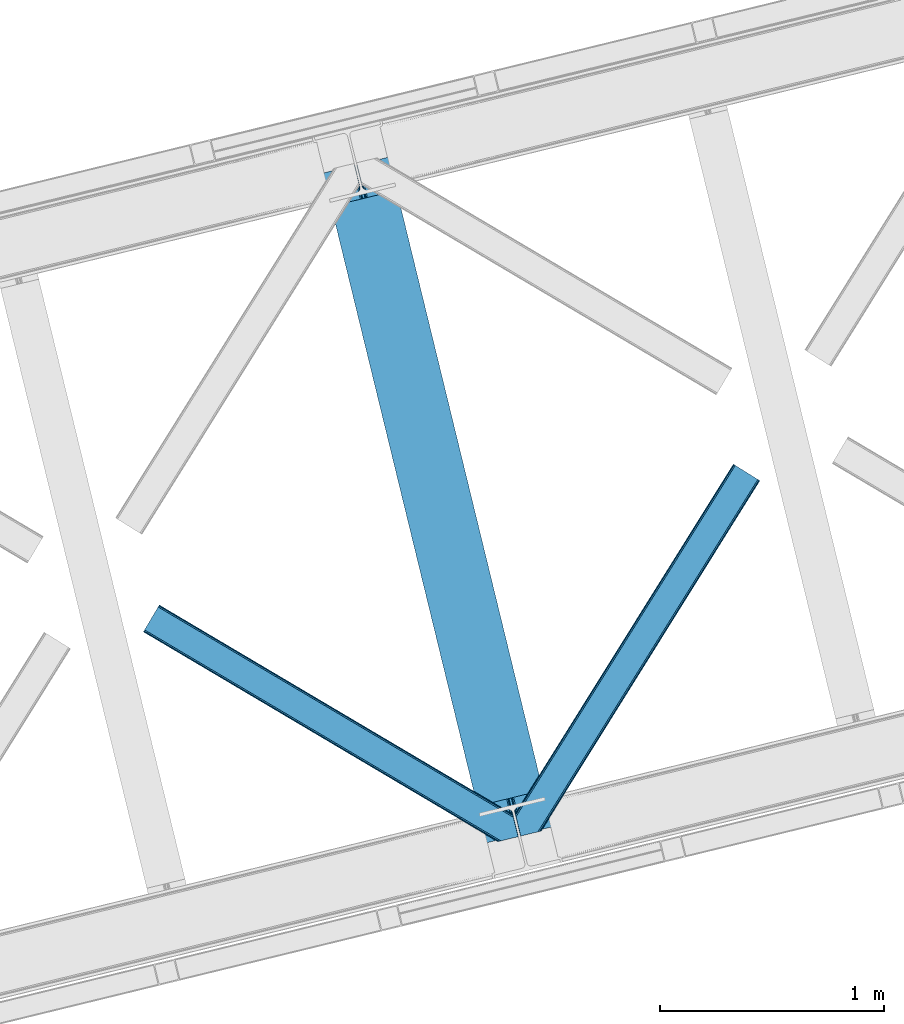
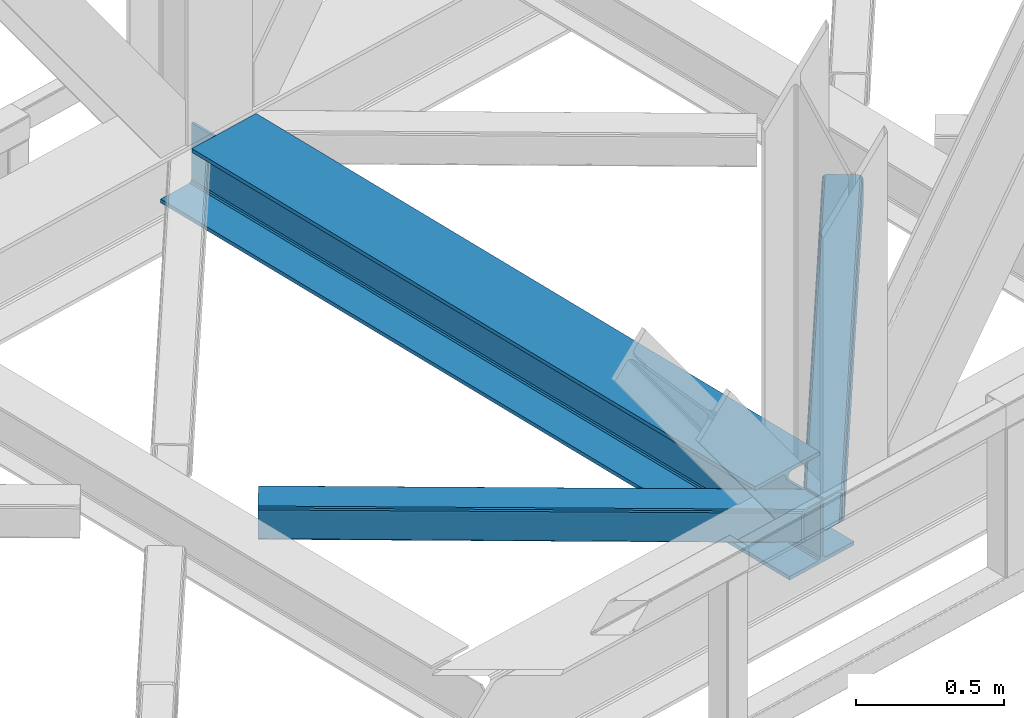
# One storey, part 62 of 92: 2 members, 1 beam.
"""IFC4 building model written with IfcOpenShell, lengths in millimetres."""

from ifc_helpers import new_model, entity, si_unit, converted_unit, derived_unit, direction, frame, origin, place, context, subcontext, project, spatial, triangles, polygons, material, type_object, element, save


model = new_model("IFC4")

# Units and contexts
model_context = context("Model", 3, precision=0.01, world=origin(), true_north=direction((6.12303176911189e-17, 1.0)))
plan_context = context("Plan", 3, precision=0.01, world=origin(), true_north=direction((6.12303176911189e-17, 1.0)))
body_context = subcontext(model_context, "Body", "Model", "MODEL_VIEW")
ifc_project = project(units=[si_unit("LENGTHUNIT", "METRE", prefix="MILLI"), si_unit("AREAUNIT", "SQUARE_METRE"), si_unit("VOLUMEUNIT", "CUBIC_METRE"), converted_unit("PLANEANGLEUNIT", "DEGREE", entity("IfcRatioMeasure", 0.0174532925199433), si_unit("PLANEANGLEUNIT", "RADIAN"), dimensions=[0, 0, 0, 0, 0, 0, 0]), si_unit("MASSUNIT", "GRAM", prefix="KILO"), derived_unit("MASSDENSITYUNIT", [(si_unit("MASSUNIT", "GRAM", prefix="KILO"), 1), (si_unit("LENGTHUNIT", "METRE"), -3)]), derived_unit("MOMENTOFINERTIAUNIT", [(si_unit("LENGTHUNIT", "METRE"), 4)]), si_unit("TIMEUNIT", "SECOND"), si_unit("FREQUENCYUNIT", "HERTZ"), si_unit("THERMODYNAMICTEMPERATUREUNIT", "DEGREE_CELSIUS"), derived_unit("THERMALTRANSMITTANCEUNIT", [(si_unit("MASSUNIT", "GRAM", prefix="KILO"), 1), (si_unit("THERMODYNAMICTEMPERATUREUNIT", "KELVIN"), -1), (si_unit("TIMEUNIT", "SECOND"), -3)]), derived_unit("VOLUMETRICFLOWRATEUNIT", [(si_unit("LENGTHUNIT", "METRE"), 3), (si_unit("TIMEUNIT", "SECOND"), -1)]), derived_unit("MASSFLOWRATEUNIT", [(si_unit("MASSUNIT", "GRAM", prefix="KILO"), 1), (si_unit("TIMEUNIT", "SECOND"), -1)]), derived_unit("ROTATIONALFREQUENCYUNIT", [(si_unit("TIMEUNIT", "SECOND"), -1)]), si_unit("ELECTRICCURRENTUNIT", "AMPERE"), si_unit("ELECTRICVOLTAGEUNIT", "VOLT"), si_unit("POWERUNIT", "WATT"), si_unit("FORCEUNIT", "NEWTON", prefix="KILO"), si_unit("ILLUMINANCEUNIT", "LUX"), si_unit("LUMINOUSFLUXUNIT", "LUMEN"), si_unit("LUMINOUSINTENSITYUNIT", "CANDELA"), derived_unit("USERDEFINED", [(si_unit("MASSUNIT", "GRAM", prefix="KILO"), -1), (si_unit("LENGTHUNIT", "METRE"), -2), (si_unit("TIMEUNIT", "SECOND"), 3), (si_unit("LUMINOUSFLUXUNIT", "LUMEN"), 1)]), derived_unit("LINEARVELOCITYUNIT", [(si_unit("LENGTHUNIT", "METRE"), 1), (si_unit("TIMEUNIT", "SECOND"), -1)]), si_unit("PRESSUREUNIT", "PASCAL"), derived_unit("USERDEFINED", [(si_unit("LENGTHUNIT", "METRE"), -2), (si_unit("MASSUNIT", "GRAM", prefix="KILO"), 1), (si_unit("TIMEUNIT", "SECOND"), -2)]), derived_unit("LINEARFORCEUNIT", [(si_unit("MASSUNIT", "GRAM", prefix="KILO"), 1), (si_unit("LENGTHUNIT", "METRE"), 1), (si_unit("TIMEUNIT", "SECOND"), -2), (si_unit("LENGTHUNIT", "METRE"), -1)]), derived_unit("PLANARFORCEUNIT", [(si_unit("MASSUNIT", "GRAM", prefix="KILO"), 1), (si_unit("LENGTHUNIT", "METRE"), 1), (si_unit("TIMEUNIT", "SECOND"), -2), (si_unit("LENGTHUNIT", "METRE"), -2)])], contexts=[model_context, plan_context])

# Site, building, storey
site_placement = place(None, origin())
site = spatial("IfcSite", under=ifc_project, at=site_placement, CompositionType="ELEMENT")
building_placement = place(site_placement, origin())
building = spatial("IfcBuilding", under=site, at=building_placement, CompositionType="ELEMENT")
storey_placement = place(building_placement, frame((0.0, 0.0, 15900.0)))
storey = spatial("IfcBuildingStorey", under=building, at=storey_placement, Name="05", CompositionType="ELEMENT", Elevation=15900.0)

# Beam
ifc_material = material(Name="Metal painted (White)")
beam_type = type_object("IfcBeamType", PredefinedType="BEAM")
beam_placement = place(storey_placement, frame((-24164.82, 11902.31, 3385.0)))
element("IfcBeam", 1, at=beam_placement, inside=storey, type_object=beam_type, material=ifc_material, ObjectType="Steel Beam", PredefinedType="BEAM", context=body_context, shape_type="Tessellation", body=[
    polygons([(1018.69934249252, 71.0478278971021, 15.4999999999986), (1018.69934249252, 71.0478278971021, 0.0), (291.465617442446, 3054.44131043503, 0.0), (291.465617442446, 3054.44131043503, 15.4999999999986), (895.312231108556, 40.9709140873291, 15.4999999999986), (168.078506058478, 3024.36439662526, 15.4999999999986), (888.619887334602, 39.3395844888221, 16.8701684147963), (161.386162284524, 3022.73306702675, 16.8701684147963), (882.946392233978, 37.9566100336497, 20.7720779386413), (155.7126671839, 3021.35009257158, 20.7720779386413), (879.155484005407, 37.0325360459184, 26.6116982174316), (151.921758955329, 3020.42601858385, 26.6116982174316), (877.824294062006, 36.7080444135007, 33.500000000001), (150.590569011932, 3020.10152695143, 33.500000000001), (140.875048430518, 3017.73326602153, 33.500000000001), (140.875048430514, 3017.73326602153, 259.000000000002), (150.590569011932, 3020.10152695143, 259.000000000002), (0.0, 2983.39348253793, 0.0), (4.33146851719357e-12, 2983.39348253793, 15.4999999999986), (123.387111383972, 3013.4703963477, 15.4999999999986), (130.079455157931, 3015.10172594621, 16.8701684147963), (135.752950258551, 3016.48470040138, 20.7720779386413), (139.543858487122, 3017.40877438911, 26.6116982174294), (877.824294062006, 36.7080444135007, 259.000000000002), (868.108773480596, 34.3397834835992, 259.000000000002), (868.108773480596, 34.3397834835992, 33.500000000001), (866.777583537199, 34.0152918511837, 26.6116982174294), (862.986675308629, 33.0912178634502, 20.7720779386413), (857.313180208009, 31.7082434082778, 16.8701684147963), (850.62083643405, 30.076913809773, 15.4999999999986), (727.233725050078, 0.0, 15.4999999999986), (727.233725050078, 0.0, 0.0), (838.124523621651, 199.571930111228, 259.069791776412), (186.469722099967, 2872.911390143, 259.000000000002), (186.69311520182, 2871.99494573803, 259.61730333112), (186.70550404545, 2871.94412150425, 266.500003008253), (837.979344808143, 200.167408132522, 266.500002998871), (837.979694928895, 200.165971827788, 260.000004007589), (828.499586340847, 196.831858094284, 259.006343172366), (828.276216326111, 197.748309612731, 259.61730333112), (828.263827482481, 197.799133846505, 266.500003008253), (176.98998671978, 2869.57584721824, 266.500002998871), (176.989636599032, 2869.57728352297, 260.000004007589), (176.844830940692, 2870.17133233676, 259.07612046749), (176.754201518552, 2870.54312921309, 259.000000000002), (839.31083267807, 200.490677577208, 273.388305639783), (843.101109266757, 201.417342749121, 279.227924098781), (848.774180214296, 202.802057212799, 283.129832400615), (855.46637189543, 204.434010743612, 284.500000377228), (978.853400583269, 234.51126379872, 284.500000138971), (978.851730776613, 234.518113867455, 299.999995328161), (687.386308679343, 163.469484603413, 299.999995890962), (687.387978485999, 163.462634534681, 284.500000701776), (810.775007173847, 193.539887589792, 284.500000463519), (817.467494069986, 195.17063005637, 283.129832461069), (823.141405718746, 196.551895700896, 279.227924137322), (826.932940505738, 197.473399350192, 273.388305663684), (175.658498849857, 2869.25257777355, 273.388305639788), (171.868222261165, 2868.32591260164, 279.227924098781), (166.195151313635, 2866.94119813796, 283.129832400619), (159.502959632502, 2865.30924460715, 284.500000377228), (36.1159309446533, 2835.23199155204, 284.500000138971), (36.1176007513094, 2835.2251414833, 299.999995328161), (327.58302284858, 2906.27377074734, 299.999995890962), (327.581353041924, 2906.28062081608, 284.500000701776), (204.194324354084, 2876.20336776097, 284.500000463519), (197.501837457945, 2874.57262529439, 283.129832461065), (191.827925809176, 2873.19135964986, 279.227924137322), (188.036391022189, 2872.26985600057, 273.388305663684)], [[[1, 2, 3, 4]], [[5, 1, 4, 6]], [[7, 5, 6, 8]], [[9, 7, 8, 10]], [[11, 9, 10, 12]], [[13, 11, 12, 14]], [[15, 16, 17, 14, 12, 10, 8, 6, 4, 3, 18, 19, 20, 21, 22, 23]], [[13, 24, 25, 26, 27, 28, 29, 30, 31, 32, 2, 1, 5, 7, 9, 11]], [[2, 32, 18, 3]], [[32, 31, 19, 18]], [[31, 30, 20, 19]], [[27, 26, 15, 23]], [[28, 27, 23, 22]], [[29, 28, 22, 21]], [[30, 29, 21, 20]], [[33, 24, 13, 14, 17, 34, 35, 36, 37, 38]], [[25, 39, 40, 41, 42, 43, 44, 16, 15, 26]], [[39, 25, 24, 33]], [[45, 34, 17, 16]], [[41, 40, 38, 37, 46, 47, 48, 49, 50, 51, 52, 53, 54, 55, 56, 57]], [[42, 58, 59, 60, 61, 62, 63, 64, 65, 66, 67, 68, 69, 36, 35, 43]], [[46, 37, 36, 69]], [[47, 46, 69, 68]], [[48, 47, 68, 67]], [[49, 48, 67, 66]], [[50, 49, 66, 65]], [[51, 50, 65, 64]], [[52, 51, 64, 63]], [[53, 52, 63, 62]], [[54, 53, 62, 61]], [[55, 54, 61, 60]], [[56, 55, 60, 59]], [[57, 56, 59, 58]], [[41, 57, 58, 42]]], closed=False),
])

# Members
member_type_1 = type_object("IfcMemberType", PredefinedType="BRACE")
member_1_placement = place(storey_placement, frame((-23308.99, 11932.7, 3510.0)))
element("IfcMember", 2, at=member_1_placement, inside=storey, type_object=member_type_1, ObjectType="Steel Horizontal Brace", PredefinedType="BRACE", context=body_context, shape_type="Tessellation", body=[
    triangles([(986.153759765624, 1647.42967529297, 0.0), (1075.22274169922, 1591.82725524902, 0.0), (119.790362548825, 259.603921508789, 0.0), (154.551031494138, 117.003323364257, 0.0), (115.904553222656, 275.544808959961, 4.52065429687718), (117.571893310545, 268.698715209961, 1.33247680664135), (158.436840820312, 101.062435913085, 4.52065429687718), (156.767175292967, 107.908529663086, 1.33247680664135), (114.825549316403, 275.742471313477, 5.52059326172093), (115.132507324219, 275.92385559082, 5.35316162109666), (158.132208251951, 99.1218566894531, 5.27525939941552), (115.441790771481, 276.107565307617, 5.18107910156323), (158.234527587891, 99.7776306152336, 5.02062377929906), (158.190344238279, 99.4822998046875, 5.13573303222802), (115.544110107421, 276.168026733398, 5.12526855468968), (115.68596191406, 275.921530151367, 4.88574829101708), (158.336846923827, 100.433404541016, 4.76482543945531), (158.032214355466, 98.4928253173821, 5.52059326172093), (1085.71977539062, 1585.27416687012, 5.12526855468968), (1080.9037902832, 1588.28096008301, 1.33247680664135), (1088.93818359375, 1583.26498718262, 10.8028289794929), (114.21163330078, 21.8533172607422, 10.8028289794929), (109.467736816405, 20.6964111328125, 5.52059326172093), (1090.06834716797, 1582.55921630859, 17.5000946044929), (116.062683105469, 22.3044525146488, 17.5000946044929), (6.75307617187354, 102.619317626953, 5.52059326172093), (31.3655273437471, 1.65803833007885, 5.52059326172093), (1090.06834716797, 1582.55921630859, 122.500662231447), (116.062683105469, 22.3044525146488, 122.500662231447), (1088.93818359375, 1583.26498718262, 129.197927856447), (114.21163330078, 21.8533172607422, 129.197927856447), (1085.71977539062, 1585.27416687012, 134.874325561526), (108.937536621092, 20.5673492431633, 134.874325561526), (1080.9037902832, 1588.28096008301, 138.667117309571), (101.042669677732, 18.6430480957024, 138.667117309571), (1075.22274169922, 1591.82725524902, 139.999594116212), (91.7292846679666, 16.3722564697273, 139.999594116212), (980.472711181639, 1650.97597045899, 1.33247680664135), (975.656726074216, 1653.98276367187, 5.12526855468968), (1.69059448242115, 100.410150146485, 10.9621215820334), (972.438317871092, 1655.99078063965, 10.8028289794929), (971.310479736327, 1656.69655151367, 17.5000946044929), (0.239520263668965, 99.7776306152336, 12.5201660156272), (0.0, 100.760128784179, 17.5000946044929), (5.79266967773219, 76.992974853516, 139.999594116212), (986.153759765624, 1647.42967529297, 139.999594116212), (24.5612915039055, 0.0, 139.999594116212), (971.310479736327, 1656.69655151367, 122.500662231447), (0.0, 100.760128784179, 122.500662231447), (980.472711181639, 1650.97597045899, 138.667117309571), (3.57652587890334, 86.0889312744148, 138.667117309571), (975.656726074216, 1653.98276367187, 134.874325561526), (1.69757080078125, 93.7989257812496, 134.874325561526), (972.438317871092, 1655.99078063965, 129.197927856447), (0.44183349609375, 98.9509368896488, 129.197927856447), (29.9260803222642, 1.30689697265552, 6.99957275390625), (12.1969299316406, 74.0326904296871, 6.99957275390625), (8.99479980468459, 81.5485107421882, 8.3320495605476), (3.88813476562427, 84.8122650146488, 12.5201660156272), (1069.28356933594, 1595.53400573731, 6.99957275390625), (81.9973205566384, 14.0003082275398, 6.99957275390625), (992.092932128904, 1643.72292480469, 6.99957275390625), (981.593572998045, 1650.27485046387, 12.1260040283232), (978.379815673827, 1652.28519287109, 17.8035644531265), (2.75797119140407, 89.4445404052731, 17.8035644531265), (986.409558105468, 1647.26805725098, 8.3320495605476), (977.245001220701, 1652.98863830566, 24.4996673583992), (2.3184631347649, 91.2537322998051, 24.4996673583992), (977.245001220701, 1652.98863830566, 115.501089477541), (2.3184631347649, 91.2537322998051, 115.501089477541), (4.01370849609157, 84.2925292968757, 127.87475280762), (2.75797119140407, 89.4445404052731, 122.196029663086), (5.89498901367188, 76.5813720703118, 131.667544555665), (8.11113281249709, 67.4865783691403, 133.000021362306), (24.5612915039055, 0.0, 133.000021362306), (978.379815673827, 1652.28519287109, 122.196029663086), (981.593572998045, 1650.27485046387, 127.87475280762), (986.409558105468, 1647.26805725098, 131.667544555665), (992.092932128904, 1643.72292480469, 133.000021362306), (1069.28356933594, 1595.53400573731, 133.000021362306), (81.9973205566384, 14.0003082275398, 133.000021362306), (1079.78060302734, 1588.9809173584, 12.1260040283232), (1082.99901123047, 1586.9717376709, 17.8035644531265), (1084.12917480469, 1586.26596679687, 24.4996673583992), (1074.96461791992, 1591.98654785156, 8.3320495605476), (1079.78060302734, 1588.9809173584, 127.87475280762), (1084.12917480469, 1586.26596679687, 115.501089477541), (1082.99901123047, 1586.9717376709, 122.196029663086), (1074.96461791992, 1591.98654785156, 131.667544555665), (91.3107055664041, 16.2699371337894, 131.667544555665), (99.2032470703125, 18.1942382812504, 127.87475280762), (104.479669189452, 19.4802062988274, 122.196029663086), (106.330718994141, 19.931341552734, 115.501089477541), (91.3107055664041, 16.2699371337894, 8.3320495605476), (104.479669189452, 19.4802062988274, 17.8035644531265), (99.2032470703125, 18.1942382812504, 12.1260040283232), (106.330718994141, 19.931341552734, 24.4996673583992)], [[1, 2, 3], [4, 3, 2], [5, 3, 4], [3, 5, 6], [4, 7, 5], [7, 4, 8], [9, 10, 11], [10, 12, 13], [13, 14, 10], [12, 15, 16], [16, 17, 12], [16, 5, 7], [7, 17, 16], [17, 13, 12], [14, 11, 10], [11, 18, 9], [19, 14, 13], [13, 20, 19], [13, 17, 20], [17, 7, 20], [7, 8, 20], [21, 22, 18], [18, 19, 21], [14, 19, 11], [18, 11, 19], [22, 23, 18], [21, 24, 25], [25, 22, 21], [2, 20, 4], [8, 4, 20], [23, 26, 18], [23, 27, 26], [9, 18, 26], [24, 28, 29], [29, 25, 24], [28, 30, 29], [31, 29, 30], [30, 32, 31], [33, 31, 32], [32, 34, 33], [35, 33, 34], [34, 36, 35], [37, 35, 36], [38, 6, 5], [5, 39, 38], [5, 15, 39], [40, 41, 9], [41, 39, 15], [42, 41, 40], [40, 43, 42], [43, 44, 42], [9, 26, 40], [38, 1, 6], [3, 6, 1], [36, 45, 37], [36, 46, 45], [45, 47, 37], [48, 42, 44], [44, 49, 48], [46, 50, 51], [51, 45, 46], [50, 52, 53], [53, 51, 50], [52, 54, 55], [55, 53, 52], [54, 48, 49], [49, 55, 54], [27, 56, 57], [26, 57, 58], [57, 26, 27], [59, 40, 26], [26, 58, 59], [43, 40, 59], [60, 57, 61], [60, 62, 57], [57, 56, 61], [63, 64, 65], [65, 59, 63], [66, 63, 59], [62, 66, 58], [58, 57, 62], [59, 58, 66], [64, 67, 68], [68, 65, 64], [67, 69, 70], [70, 68, 67], [71, 53, 72], [73, 74, 45], [74, 47, 45], [74, 75, 47], [51, 73, 45], [71, 51, 53], [71, 73, 51], [49, 68, 70], [55, 72, 53], [70, 72, 49], [72, 55, 49], [44, 68, 49], [43, 59, 65], [65, 68, 44], [44, 43, 65], [69, 76, 70], [72, 70, 76], [76, 77, 72], [71, 72, 77], [77, 78, 71], [73, 71, 78], [78, 79, 73], [74, 73, 79], [80, 74, 79], [74, 80, 81], [75, 74, 81], [21, 82, 83], [84, 28, 24], [21, 83, 24], [21, 19, 82], [83, 84, 24], [82, 19, 20], [60, 2, 1], [2, 85, 20], [85, 2, 60], [85, 82, 20], [30, 86, 32], [87, 28, 84], [28, 88, 30], [88, 28, 87], [30, 88, 86], [36, 80, 46], [34, 32, 86], [86, 89, 34], [89, 80, 36], [36, 34, 89], [63, 38, 39], [1, 62, 60], [1, 66, 62], [66, 1, 38], [63, 66, 38], [67, 42, 48], [41, 64, 63], [39, 41, 63], [64, 41, 42], [67, 64, 42], [50, 77, 52], [46, 80, 79], [79, 78, 46], [78, 77, 50], [50, 46, 78], [54, 52, 77], [48, 69, 67], [76, 48, 54], [48, 76, 69], [76, 54, 77], [35, 37, 90], [47, 81, 37], [81, 47, 75], [81, 90, 37], [91, 35, 90], [91, 33, 35], [33, 92, 31], [92, 33, 91], [29, 92, 93], [92, 29, 31], [61, 23, 94], [95, 96, 23], [96, 94, 23], [61, 27, 23], [27, 61, 56], [97, 95, 25], [22, 25, 95], [29, 97, 25], [97, 29, 93], [95, 23, 22], [80, 89, 90], [90, 81, 80], [89, 86, 91], [91, 90, 89], [86, 88, 92], [92, 91, 86], [88, 87, 93], [93, 92, 88], [87, 84, 93], [97, 93, 84], [84, 83, 97], [95, 97, 83], [83, 82, 95], [96, 95, 82], [82, 85, 96], [94, 96, 85], [85, 60, 94], [61, 94, 60]]),
])
member_type_2 = type_object("IfcMemberType", PredefinedType="BRACE")
member_2_placement = place(storey_placement, frame((-24965.59, 11907.55, 3510.0)))
element("IfcMember", 3, at=member_2_placement, inside=storey, type_object=member_type_2, ObjectType="Steel Horizontal Brace", PredefinedType="BRACE", context=body_context, shape_type="Tessellation", body=[
    triangles([(1465.49659423828, 208.965151977538, 0.0), (1500.25726318359, 66.3657165527347, 0.0), (8.91340942382885, 949.276940917969, 0.0), (62.4054931640603, 1039.62956542969, 0.0), (0.676702880857192, 935.363836669922, 10.8028289794929), (1580.23145141601, 0.541827392577034, 10.8679412841811), (1578.00600585937, 0.0, 17.5000946044929), (1506.61734008789, 44.5007720947269, 9.52034912109593), (2.60914306640552, 938.628753662109, 5.12526855468968), (1504.3546875, 49.5597656249993, 5.12526855468968), (1505.23137817383, 45.9657989501957, 8.52041015625218), (1505.92435913086, 45.2332855224613, 9.02037963867406), (1506.28247680664, 44.8554016113285, 9.27850341796875), (1505.56624145508, 45.6123321533196, 8.76225585937573), (1580.68258666992, 0.652285766600471, 9.52034912109593), (1502.47573242187, 57.2697601318359, 1.33247680664135), (5.50198974609157, 943.514501953125, 1.33247680664135), (0.0, 934.218557739257, 17.5000946044929), (1578.00600585937, 0.0, 122.500662231447), (0.0, 934.218557739257, 122.500662231447), (1593.02601928711, 3.66140441894458, 138.667117309571), (1602.33940429688, 5.93103332519422, 139.999594116212), (8.91340942382885, 949.276940917969, 139.999594116212), (5.50198974609157, 943.514501953125, 138.667117309571), (1585.13115234375, 1.73710327148365, 134.874325561526), (2.60914306640552, 938.628753662109, 134.874325561526), (1579.85938110351, 0.451135253906614, 129.197927856447), (0.676702880857192, 935.363836669922, 129.197927856447), (1500.3014465332, 66.183169555663, 8.52041015625218), (1500.65956420899, 65.0402160644535, 8.90294494629052), (1501.15023193359, 64.3216552734375, 9.10758361816625), (1501.64787597656, 63.5914672851559, 9.31571044922021), (1502.13854370117, 62.8729064941399, 9.52034912109593), (1599.49306640625, 5.23688964843677, 9.52034912109593), (9.06688842773292, 949.537390136718, 8.3320495605476), (1500.15029296875, 66.8063873291012, 8.42274169922166), (6.1786926269524, 944.652804565429, 12.1260040283232), (1594.86544189453, 4.10905151367115, 12.1260040283232), (1497.94112548828, 75.8721130371086, 6.99957275390625), (12.4806335449211, 955.300991821288, 6.99957275390625), (1589.59134521484, 2.82424621581958, 17.8035644531265), (4.24392700195313, 941.387887573243, 17.8035644531265), (1587.74029541016, 2.3719482421875, 24.4996673583992), (3.56489868164135, 940.241445922851, 24.4996673583992), (1467.81505737305, 199.458755493164, 6.99957275390625), (58.8405944824226, 1033.60667724609, 6.99957275390625), (1460.5248046875, 229.365069580077, 8.52041015625218), (1465.45241088867, 209.14769897461, 8.52041015625218), (1461.40149536133, 225.771102905273, 5.12526855468968), (1465.60588989258, 208.524481201172, 8.42274169922166), (1463.28045043945, 218.061108398437, 1.33247680664135), (1587.74029541016, 2.3719482421875, 115.501089477541), (3.56489868164135, 940.241445922851, 115.501089477541), (1589.59134521484, 2.82424621581958, 122.196029663086), (4.24392700195313, 941.387887573243, 122.196029663086), (1594.86544189453, 4.10905151367115, 127.87475280762), (6.1786926269524, 944.652804565429, 127.87475280762), (1602.76030883789, 6.03451538085938, 131.667544555665), (9.06688842773292, 949.537390136718, 131.667544555665), (1612.0713684082, 8.30298156738172, 133.000021362306), (12.4806335449211, 955.300991821288, 133.000021362306), (1669.50739746094, 22.3044525146488, 139.999594116212), (1669.50739746094, 22.3044525146488, 133.000021362306), (1650.73877563476, 99.297427368163, 139.999594116212), (62.4054931640603, 1039.62956542969, 139.999594116212), (1653.05723876953, 89.7910308837891, 133.000021362306), (58.8405944824226, 1033.60667724609, 133.000021362306), (1645.38793945313, 121.255389404296, 129.197927856447), (1644.94610595703, 123.064581298828, 122.500662231447), (70.642199707032, 1053.54266967773, 129.197927856447), (71.3212280273438, 1054.68911132813, 122.500662231447), (1646.64367675781, 116.103378295898, 134.874325561526), (68.7097595214836, 1050.27891540527, 134.874325561526), (1648.52263183594, 108.393383789062, 138.667117309571), (65.8192382812485, 1045.39316711426, 138.667117309571), (1644.94610595703, 123.064581298828, 17.5000946044929), (71.3212280273438, 1054.68911132813, 17.5000946044929), (70.642199707032, 1053.54266967773, 10.8028289794929), (65.1425354003914, 1044.25486450195, 12.1260040283232), (67.0773010253906, 1047.51861877441, 17.8035644531265), (67.7540039062478, 1048.6650604248, 24.4996673583992), (68.7097595214836, 1050.27891540527, 5.12526855468968), (65.8192382812485, 1045.39316711426, 1.33247680664135), (62.2496887207017, 1039.36911621094, 8.3320495605476), (65.1425354003914, 1044.25486450195, 127.87475280762), (67.7540039062478, 1048.6650604248, 115.501089477541), (67.0773010253906, 1047.51861877441, 122.196029663086), (62.2496887207017, 1039.36911621094, 131.667544555665), (1647.26224365234, 113.558184814452, 24.4996673583992), (1647.26224365234, 113.558184814452, 115.501089477541), (1650.83876953125, 98.8858245849606, 131.667544555665), (1648.95981445312, 106.596981811523, 127.87475280762), (1647.70407714844, 111.748992919922, 122.196029663086), (1647.79244384765, 111.385061645507, 17.8686767578147), (1647.90173950195, 110.943228149414, 16.5199218750022), (1644.95540771484, 123.027374267578, 16.5199218750022), (1638.66509399414, 124.970278930663, 10.8702667236357), (1460.74572143555, 229.701095581055, 9.22734375000073), (1460.63410034179, 229.532501220703, 8.87387695312646), (1461.54334716797, 229.405764770507, 9.52034912109593), (1637.16286010742, 125.435366821288, 9.52034912109593), (1643.67409057617, 109.725860595703, 12.1260040283232), (1466.02214355469, 211.033630371094, 9.52034912109593), (1641.64165649414, 107.063232421875, 9.52034912109593)], [[1, 2, 3], [3, 4, 1], [5, 6, 7], [6, 5, 8], [5, 9, 10], [10, 11, 5], [12, 13, 5], [13, 8, 5], [5, 14, 12], [5, 11, 14], [8, 15, 6], [16, 10, 9], [9, 17, 16], [2, 16, 17], [17, 3, 2], [7, 18, 5], [7, 19, 20], [20, 18, 7], [21, 22, 23], [23, 24, 21], [25, 21, 24], [24, 26, 25], [27, 25, 26], [26, 28, 27], [19, 27, 28], [28, 20, 19], [11, 29, 30], [14, 30, 31], [12, 31, 32], [13, 32, 33], [33, 8, 13], [32, 13, 12], [31, 12, 14], [30, 14, 11], [34, 15, 33], [8, 33, 15], [35, 30, 29], [32, 35, 33], [35, 32, 31], [30, 35, 31], [29, 36, 35], [37, 38, 33], [33, 35, 37], [38, 34, 33], [35, 36, 39], [39, 40, 35], [41, 38, 37], [37, 42, 41], [43, 41, 42], [42, 44, 43], [39, 45, 40], [46, 40, 45], [1, 45, 39], [47, 48, 49], [48, 50, 1], [45, 1, 50], [48, 51, 49], [48, 1, 51], [2, 1, 39], [2, 39, 36], [29, 2, 36], [11, 10, 29], [29, 16, 2], [29, 10, 16], [52, 43, 53], [44, 53, 43], [54, 52, 55], [53, 55, 52], [56, 54, 57], [55, 57, 54], [58, 56, 59], [57, 59, 56], [60, 58, 61], [59, 61, 58], [56, 58, 21], [25, 56, 21], [25, 27, 54], [56, 25, 54], [54, 27, 19], [58, 22, 21], [62, 60, 63], [62, 22, 60], [58, 60, 22], [54, 19, 52], [43, 7, 41], [19, 43, 52], [7, 6, 41], [19, 7, 43], [15, 41, 6], [38, 41, 15], [34, 38, 15], [22, 64, 23], [22, 62, 64], [65, 23, 64], [66, 60, 61], [60, 66, 63], [61, 67, 66], [68, 69, 70], [71, 70, 69], [72, 68, 73], [70, 73, 68], [74, 72, 75], [73, 75, 72], [64, 74, 65], [75, 65, 74], [69, 76, 77], [77, 71, 69], [78, 79, 80], [81, 71, 77], [78, 80, 77], [78, 82, 79], [80, 81, 77], [79, 82, 83], [46, 4, 3], [4, 84, 83], [84, 4, 46], [84, 79, 83], [70, 85, 73], [86, 71, 81], [71, 87, 70], [87, 71, 86], [70, 87, 85], [65, 67, 23], [75, 73, 85], [85, 88, 75], [88, 67, 65], [65, 75, 88], [37, 17, 9], [3, 40, 46], [3, 35, 40], [35, 3, 17], [37, 35, 17], [44, 18, 20], [5, 42, 37], [9, 5, 37], [42, 5, 18], [44, 42, 18], [24, 57, 26], [23, 67, 61], [61, 59, 23], [59, 57, 24], [24, 23, 59], [28, 26, 57], [20, 53, 44], [55, 20, 28], [20, 55, 53], [55, 28, 57], [89, 90, 81], [86, 81, 90], [91, 66, 67], [67, 88, 91], [92, 91, 88], [88, 85, 92], [93, 92, 85], [85, 87, 93], [90, 93, 87], [87, 86, 90], [92, 72, 74], [66, 91, 64], [91, 92, 74], [94, 95, 96], [63, 66, 62], [64, 62, 66], [91, 74, 64], [94, 76, 89], [69, 90, 89], [89, 76, 69], [94, 96, 76], [69, 93, 90], [93, 72, 92], [72, 93, 68], [69, 68, 93], [77, 76, 97], [76, 96, 97], [98, 99, 82], [47, 82, 99], [47, 49, 82], [78, 97, 100], [100, 82, 78], [100, 98, 82], [97, 101, 100], [51, 1, 4], [4, 83, 51], [49, 51, 83], [83, 82, 49], [97, 78, 77], [80, 79, 102], [102, 95, 80], [80, 94, 89], [46, 45, 50], [103, 102, 79], [103, 104, 102], [50, 79, 84], [50, 103, 79], [50, 84, 46], [89, 81, 80], [95, 94, 80], [96, 102, 97], [102, 96, 95], [102, 101, 97], [102, 104, 101], [101, 104, 103], [103, 100, 101]]),
])

save(model, "model.ifc")
